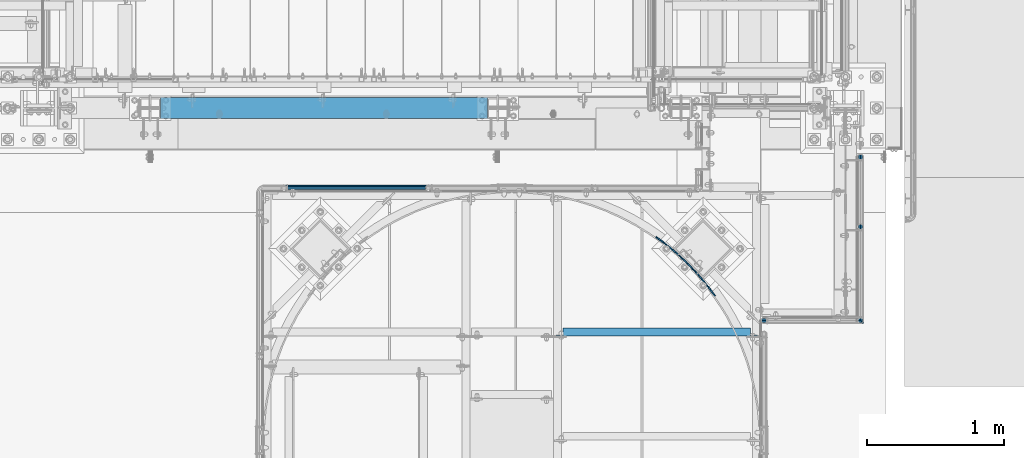
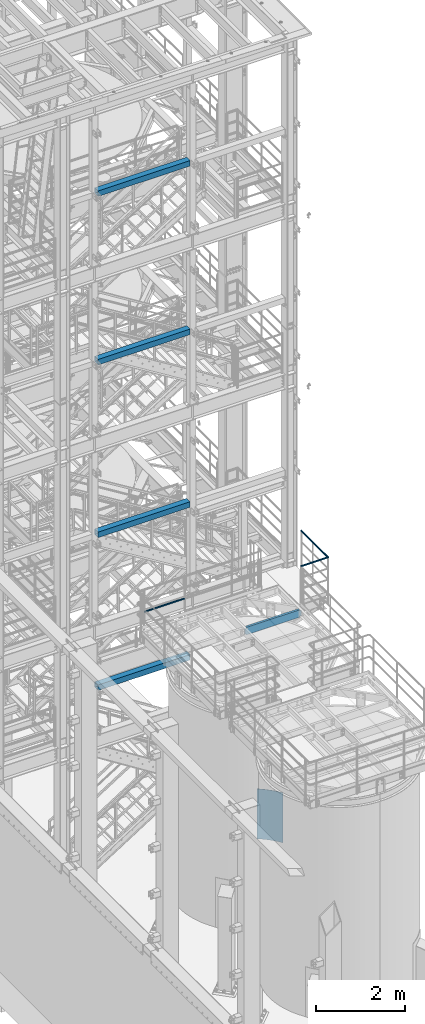
# One storey, part 943 of 1876: 8 beams, 8 elements without a shape of their own.
"""IFC2X3 building model written with IfcOpenShell, lengths in millimetres."""

import ifcopenshell
import ifcopenshell.guid

model = None  # the IFC model being written
_history = None  # IfcOwnerHistory: only IFC2X3 demands one
_inside = {}  # id of a spatial element -> (the spatial element, [elements in it])
_under = {}  # id of a project, library or spatial element -> (it, [spatial elements below it])
_declared = {}  # id of a project -> (the project, [libraries it declares])
_typed = {}  # id of a type object -> (the type object, [elements of that type])
_made_of = {}  # id of a material, layer set ... -> (it, [elements and type objects made of it])


def new_model(schema):
    """Start an empty IFC model of exactly this schema.

    Asked for "IFC4X3", IfcOpenShell would pick the latest addendum, in which some entities
    have other attributes; the version numbers below select the first issue.
    IFC2X3 requires an IfcOwnerHistory on every rooted entity: one is made here for all.
    """
    global model, _history
    if schema == "IFC4X3":
        model = ifcopenshell.file(schema_version=(4, 3, 0, 0))
    else:
        model = ifcopenshell.file(schema=schema)
    _inside.clear()
    _under.clear()
    _declared.clear()
    _typed.clear()
    _made_of.clear()
    _history = None
    if model.schema == "IFC2X3":
        org = make("IfcOrganization", Name="unknown")
        user = make(
            "IfcPersonAndOrganization",
            ThePerson=make("IfcPerson", FamilyName="unknown"),
            TheOrganization=org,
        )
        app = make(
            "IfcApplication",
            ApplicationDeveloper=org,
            Version="unknown",
            ApplicationFullName="unknown",
            ApplicationIdentifier="unknown",
        )
        _history = make(
            "IfcOwnerHistory",
            OwningUser=user,
            OwningApplication=app,
            ChangeAction="ADDED",
            CreationDate=0,
        )
    return model


def make(cls, **values):
    """One entity of the class cls with the attributes given. An attribute that is None is left unset."""
    return model.create_entity(
        cls, **{name: value for name, value in values.items() if value is not None}
    )


def rooted(cls, **values):
    """An entity with a GlobalId (a new one), such as an element, a storey or a relation."""
    return make(cls, GlobalId=ifcopenshell.guid.new(), OwnerHistory=_history, **values)


def si_unit(unit_type, name, prefix=None):
    """IfcSIUnit, for example si_unit("LENGTHUNIT", "METRE", prefix="MILLI")."""
    return make("IfcSIUnit", UnitType=unit_type, Prefix=prefix, Name=name)


def assignment(units):
    """IfcUnitAssignment: the units of a project."""
    return None if units is None else make("IfcUnitAssignment", Units=units)


def point(xyz):
    """IfcCartesianPoint."""
    return None if xyz is None else make("IfcCartesianPoint", Coordinates=xyz)


def direction(xyz):
    """IfcDirection."""
    return None if xyz is None else make("IfcDirection", DirectionRatios=xyz)


def frame(location, z_axis=None, x_axis=None):
    """IfcAxis2Placement3D, a coordinate frame: its origin and axes. An axis left out is left unset."""
    return make(
        "IfcAxis2Placement3D",
        Location=point(location),
        Axis=direction(z_axis),
        RefDirection=direction(x_axis),
    )


def origin_with_axes():
    """The frame at (0, 0, 0) with the z axis (0, 0, 1) and the x axis (1, 0, 0) written out."""
    return frame((0.0, 0.0, 0.0), z_axis=(0.0, 0.0, 1.0), x_axis=(1.0, 0.0, 0.0))


def place(relative_to, where):
    """IfcLocalPlacement: puts the frame where relative to a parent placement (None: the world)."""
    return make(
        "IfcLocalPlacement", PlacementRelTo=relative_to, RelativePlacement=where
    )


def context(
    kind, dimensions, precision=None, world=None, true_north=None, identifier=None
):
    """IfcGeometricRepresentationContext, for example the 3D "Model" context."""
    return make(
        "IfcGeometricRepresentationContext",
        ContextIdentifier=identifier,
        ContextType=kind,
        CoordinateSpaceDimension=dimensions,
        Precision=precision,
        WorldCoordinateSystem=world,
        TrueNorth=true_north,
    )


def subcontext(parent, identifier, kind, view, scale=None):
    """IfcGeometricRepresentationSubContext, for example "Body" below "Model"."""
    return make(
        "IfcGeometricRepresentationSubContext",
        ContextIdentifier=identifier,
        ContextType=kind,
        ParentContext=parent,
        TargetScale=scale,
        TargetView=view,
    )


def project(units=None, contexts=None):
    """IfcProject with its units and contexts."""
    return rooted(
        "IfcProject",
        Name="project",
        RepresentationContexts=contexts,
        UnitsInContext=assignment(units),
    )


def spatial(cls, under=None, at=None, **own):
    """A site, building, storey or space (cls), placed at a placement, below another one or the project."""
    s = rooted(cls, ObjectPlacement=at, **own)
    if under is not None:
        _under.setdefault(under.id(), (under, []))[1].append(s)
    return s


def faces_of(points, faces, orient=None, outer=None):
    """IfcFace entities. A face is a list of loops; a loop is a list of indices into points, from 0.

    orient and outer hold one flag for each loop. By default every Orientation is true, the
    first loop of a face is its IfcFaceOuterBound and the others are IfcFaceBound.
    """
    made = []
    for i, loops in enumerate(faces):
        bounds = []
        for j, loop in enumerate(loops):
            is_outer = j == 0 if outer is None else outer[i][j]
            bounds.append(
                make(
                    "IfcFaceOuterBound" if is_outer else "IfcFaceBound",
                    Bound=make("IfcPolyLoop", Polygon=[points[k] for k in loop]),
                    Orientation=True if orient is None else orient[i][j],
                )
            )
        made.append(make("IfcFace", Bounds=bounds))
    return made


def faceted_brep(points, faces, orient=None, outer=None, voids=None):
    """IfcFacetedBrep: a solid bounded by flat faces; with voids (closed shells), ...WithVoids."""
    shared = [point(p) for p in points]
    hull = make("IfcClosedShell", CfsFaces=faces_of(shared, faces, orient, outer))
    if voids is None:
        return make("IfcFacetedBrep", Outer=hull)
    return make(
        "IfcFacetedBrepWithVoids",
        Outer=hull,
        Voids=[
            make(cls, CfsFaces=faces_of(shared, fs, o, b)) for cls, fs, o, b in voids
        ],
    )


def shape(context_of_items, identifier, shape_type, items):
    """IfcShapeRepresentation: the items that make up one representation, for example the "Body"."""
    return make(
        "IfcShapeRepresentation",
        ContextOfItems=context_of_items,
        RepresentationIdentifier=identifier,
        RepresentationType=shape_type,
        Items=items,
    )


def material(Name=None, Category=None):
    """IfcMaterial."""
    return make("IfcMaterial", Name=Name, Category=Category)


def made_of(thing, what):
    """Note that an element or type object is made of a material, layer set ...; save() writes the relation."""
    if what is not None:
        _made_of.setdefault(what.id(), (what, []))[1].append(thing)
    return thing


def type_object(cls, material=None, **own):
    """A type object (cls), such as IfcWallType, which elements share."""
    return made_of(rooted(cls, **own), material)


def element(
    cls,
    number,
    at=None,
    inside=None,
    cuts=None,
    type_object=None,
    material=None,
    context=None,
    identifier="Body",
    shape_type=None,
    held_by="IfcProductDefinitionShape",
    body=None,
    shapes=None,
    **own,
):
    """One element of the class cls, such as IfcWall. Its Tag is "e" and its number.

    at: its placement. inside: the storey or other place that contains it. cuts: it is an
    opening in that element (IfcRelVoidsElement). A single representation is given by context,
    identifier, shape_type and body (its items); several are given by shapes. held_by: the class
    of the entity that holds the representations. save() writes the other relations.
    """
    e = rooted(cls, Tag="e%d" % number, ObjectPlacement=at, **own)
    if body is not None:
        shapes = [shape(context, identifier, shape_type, body)]
    if shapes is not None:
        e.Representation = make(held_by, Representations=shapes)
    if inside is not None:
        _inside.setdefault(inside.id(), (inside, []))[1].append(e)
    if cuts is not None:
        rooted(
            "IfcRelVoidsElement", RelatingBuildingElement=cuts, RelatedOpeningElement=e
        )
    if type_object is not None:
        _typed.setdefault(type_object.id(), (type_object, []))[1].append(e)
    return made_of(e, material)


def aggregate(whole, parts):
    """IfcRelAggregates: a whole, such as a stair, and the parts it consists of."""
    return rooted("IfcRelAggregates", RelatingObject=whole, RelatedObjects=parts)


def save(model, path):
    """Write the relations noted so far, then the file.

    IfcRelAggregates (storeys below a building ...), IfcRelContainedInSpatialStructure (elements
    in a storey), IfcRelDefinesByType, IfcRelAssociatesMaterial and IfcRelDeclares: one each for
    every whole, place, type object, material and project.
    """
    for whole, parts in _under.values():
        aggregate(whole, parts)
    for where, things in _inside.values():
        rooted(
            "IfcRelContainedInSpatialStructure",
            RelatedElements=things,
            RelatingStructure=where,
        )
    for kind, things in _typed.values():
        rooted("IfcRelDefinesByType", RelatedObjects=things, RelatingType=kind)
    for what, things in _made_of.values():
        rooted("IfcRelAssociatesMaterial", RelatedObjects=things, RelatingMaterial=what)
    for by, libraries in _declared.values():
        rooted("IfcRelDeclares", RelatingContext=by, RelatedDefinitions=libraries)
    model.write(path)


model = new_model("IFC2X3")

# Units and contexts
model_context = context("Model", 3, precision=1e-05, world=origin_with_axes())
body_context = subcontext(model_context, "Body", "Model", "MODEL_VIEW")
ifc_project = project(units=[si_unit("LENGTHUNIT", "METRE", prefix="MILLI"), si_unit("AREAUNIT", "SQUARE_METRE"), si_unit("VOLUMEUNIT", "CUBIC_METRE"), si_unit("MASSUNIT", "GRAM", prefix="KILO"), si_unit("TIMEUNIT", "SECOND"), si_unit("PLANEANGLEUNIT", "RADIAN"), si_unit("SOLIDANGLEUNIT", "STERADIAN"), si_unit("THERMODYNAMICTEMPERATUREUNIT", "DEGREE_CELSIUS"), si_unit("LUMINOUSINTENSITYUNIT", "LUMEN")], contexts=[model_context])

# Site, building, storey
site_placement = place(None, origin_with_axes())
site = spatial("IfcSite", under=ifc_project, at=site_placement, CompositionType="ELEMENT")
building_placement = place(site_placement, origin_with_axes())
building = spatial("IfcBuilding", under=site, at=building_placement, Name="Undefined", CompositionType="ELEMENT")
storey_placement = place(building_placement, origin_with_axes())
storey = spatial("IfcBuildingStorey", under=building, at=storey_placement, Name="Undefined", CompositionType="ELEMENT", Elevation=0.0)

# Assembly, beam
assembly_1_placement = place(storey_placement, origin_with_axes())
assembly_1 = element("IfcElementAssembly", 1, at=assembly_1_placement, inside=storey, Name="FRAME", AssemblyPlace="NOTDEFINED", PredefinedType="RIGID_FRAME")
ifc_material_1 = material()
beam_type_1 = type_object("IfcBeamType", Name="HSS6X6X3/8", PredefinedType="NOTDEFINED")
beam_1_placement = place(assembly_1_placement, frame((2540.0, -7112.0, 19958.05), z_axis=(0.0, 1.0, 0.0), x_axis=(1.0, 0.0, 0.0)))
beam_1 = element("IfcBeam", 2, at=beam_1_placement, type_object=beam_type_1, material=ifc_material_1, Name="FRAME", ObjectType="HSS6X6X3/8", context=body_context, shape_type="Brep", body=[
    faceted_brep([(76.2000000000007, 66.6749999999993, -66.6750000000002), (76.2000000000007, -66.6749999999993, -66.6750000000002), (2463.8, -66.6749999999993, -66.6750000000002), (2463.8, 66.6749999999993, -66.6750000000002), (76.2000000000007, -66.6749999999993, 66.6750000000002), (2463.8, -66.6749999999993, 66.6750000000002), (76.2000000000007, 66.6749999999993, 66.6750000000002), (2463.8, 66.6749999999993, 66.6750000000002), (76.2000000000007, 76.2000000000007, -76.1999999999998), (76.2000000000007, 76.2000000000007, 76.1999999999998), (2463.8, 76.2000000000007, 76.1999999999998), (2463.8, 76.2000000000007, -76.1999999999998), (76.2000000000007, -76.2000000000007, 76.1999999999998), (2463.8, -76.2000000000007, 76.1999999999998), (76.2000000000007, -76.2000000000007, -76.1999999999998), (2463.8, -76.2000000000007, -76.1999999999998)], [[[0, 1, 2, 3]], [[1, 4, 5, 2]], [[4, 6, 7, 5]], [[6, 0, 3, 7]], [[8, 9, 10, 11]], [[9, 12, 13, 10]], [[12, 14, 15, 13]], [[14, 8, 11, 15]], [[13, 15, 11, 10], [5, 7, 3, 2]], [[14, 12, 9, 8], [6, 4, 1, 0]]]),
])
aggregate(assembly_1, [beam_1])

assembly_2_placement = place(storey_placement, origin_with_axes())
assembly_2 = element("IfcElementAssembly", 3, at=assembly_2_placement, inside=storey, Name="FRAME", AssemblyPlace="NOTDEFINED", PredefinedType="RIGID_FRAME")
beam_2_placement = place(assembly_2_placement, frame((2540.0, -7112.0, 15335.25), z_axis=(0.0, 1.0, 0.0), x_axis=(1.0, 0.0, 0.0)))
beam_2 = element("IfcBeam", 4, at=beam_2_placement, type_object=beam_type_1, material=ifc_material_1, Name="FRAME", ObjectType="HSS6X6X3/8", context=body_context, shape_type="Brep", body=[
    faceted_brep([(76.2000000000007, 66.6749999999993, -66.6750000000002), (76.2000000000007, -66.6749999999993, -66.6750000000002), (2463.8, -66.6749999999993, -66.6750000000002), (2463.8, 66.6749999999993, -66.6750000000002), (76.2000000000007, -66.6749999999993, 66.6750000000002), (2463.8, -66.6749999999993, 66.6750000000002), (76.2000000000007, 66.6749999999993, 66.6750000000002), (2463.8, 66.6749999999993, 66.6750000000002), (76.2000000000007, 76.2000000000007, -76.1999999999998), (76.2000000000007, 76.2000000000007, 76.1999999999998), (2463.8, 76.2000000000007, 76.1999999999998), (2463.8, 76.2000000000007, -76.1999999999998), (76.2000000000007, -76.2000000000007, 76.1999999999998), (2463.8, -76.2000000000007, 76.1999999999998), (76.2000000000007, -76.2000000000007, -76.1999999999998), (2463.8, -76.2000000000007, -76.1999999999998)], [[[0, 1, 2, 3]], [[1, 4, 5, 2]], [[4, 6, 7, 5]], [[6, 0, 3, 7]], [[8, 9, 10, 11]], [[9, 12, 13, 10]], [[12, 14, 15, 13]], [[14, 8, 11, 15]], [[13, 15, 11, 10], [5, 7, 3, 2]], [[14, 12, 9, 8], [6, 4, 1, 0]]]),
])
aggregate(assembly_2, [beam_2])

assembly_3_placement = place(storey_placement, origin_with_axes())
assembly_3 = element("IfcElementAssembly", 5, at=assembly_3_placement, inside=storey, Name="FRAME", AssemblyPlace="NOTDEFINED", PredefinedType="RIGID_FRAME")
beam_3_placement = place(assembly_3_placement, frame((2540.0, -7112.0, 10598.15), z_axis=(0.0, 1.0, 0.0), x_axis=(1.0, 0.0, 0.0)))
beam_3 = element("IfcBeam", 6, at=beam_3_placement, type_object=beam_type_1, material=ifc_material_1, Name="FRAME", ObjectType="HSS6X6X3/8", context=body_context, shape_type="Brep", body=[
    faceted_brep([(76.2000000000007, 66.6749999999993, -66.6750000000002), (76.2000000000007, -66.6749999999993, -66.6750000000002), (2463.8, -66.6749999999993, -66.6750000000002), (2463.8, 66.6749999999993, -66.6750000000002), (76.2000000000007, -66.6749999999993, 66.6750000000002), (2463.8, -66.6749999999993, 66.6750000000002), (76.2000000000007, 66.6749999999993, 66.6750000000002), (2463.8, 66.6749999999993, 66.6750000000002), (76.2000000000007, 76.2000000000007, -76.1999999999998), (76.2000000000007, 76.2000000000007, 76.1999999999998), (2463.8, 76.2000000000007, 76.1999999999998), (2463.8, 76.2000000000007, -76.1999999999998), (76.2000000000007, -76.2000000000007, 76.1999999999998), (2463.8, -76.2000000000007, 76.1999999999998), (76.2000000000007, -76.2000000000007, -76.1999999999998), (2463.8, -76.2000000000007, -76.1999999999998)], [[[0, 1, 2, 3]], [[1, 4, 5, 2]], [[4, 6, 7, 5]], [[6, 0, 3, 7]], [[8, 9, 10, 11]], [[9, 12, 13, 10]], [[12, 14, 15, 13]], [[14, 8, 11, 15]], [[13, 15, 11, 10], [5, 7, 3, 2]], [[14, 12, 9, 8], [6, 4, 1, 0]]]),
])
aggregate(assembly_3, [beam_3])

assembly_4_placement = place(storey_placement, origin_with_axes())
assembly_4 = element("IfcElementAssembly", 7, at=assembly_4_placement, inside=storey, Name="FRAME", AssemblyPlace="NOTDEFINED", PredefinedType="RIGID_FRAME")
beam_4_placement = place(assembly_4_placement, frame((2539.98075746042, -7112.0, 6407.15001063849), z_axis=(0.0, 1.0, 0.0), x_axis=(1.0, 0.0, 0.0)))
beam_4 = element("IfcBeam", 8, at=beam_4_placement, type_object=beam_type_1, material=ifc_material_1, Name="FRAME", ObjectType="HSS6X6X3/8", context=body_context, shape_type="Brep", body=[
    faceted_brep([(76.2192425395833, 66.6750000000002, -66.6750000000002), (76.2192425395833, -66.6750000000002, -66.6750000000002), (2463.81924253958, -66.6750000000002, -66.6750000000002), (2463.81924253958, 66.6750000000002, -66.6750000000002), (76.2192425395833, -66.6750000000002, 66.6750000000002), (2463.81924253958, -66.6750000000002, 66.6750000000002), (76.2192425395833, 66.6750000000002, 66.6750000000002), (2463.81924253958, 66.6750000000002, 66.6750000000002), (76.2192425395833, 76.1999999999998, -76.1999999999998), (76.2192425395833, 76.1999999999998, 76.1999999999998), (2463.81924253958, 76.1999999999998, 76.1999999999998), (2463.81924253958, 76.1999999999998, -76.1999999999998), (76.2192425395833, -76.1999999999998, 76.1999999999998), (2463.81924253958, -76.1999999999998, 76.1999999999998), (76.2192425395833, -76.1999999999998, -76.1999999999998), (2463.81924253958, -76.1999999999998, -76.1999999999998)], [[[0, 1, 2, 3]], [[1, 4, 5, 2]], [[4, 6, 7, 5]], [[6, 0, 3, 7]], [[8, 9, 10, 11]], [[9, 12, 13, 10]], [[12, 14, 15, 13]], [[14, 8, 11, 15]], [[13, 15, 11, 10], [5, 7, 3, 2]], [[14, 12, 9, 8], [6, 4, 1, 0]]]),
])
aggregate(assembly_4, [beam_4])

assembly_5_placement = place(storey_placement, origin_with_axes())
assembly_5 = element("IfcElementAssembly", 9, at=assembly_5_placement, inside=storey, Name="HANDRAIL", AssemblyPlace="NOTDEFINED", PredefinedType="RIGID_FRAME")
ifc_material_2 = material()
beam_type_2 = type_object("IfcBeamType", Name="PIPE1-1/4STD", PredefinedType="NOTDEFINED")
beam_5_placement = place(assembly_5_placement, frame((7729.98183904197, -7448.10549924137, 9090.025), z_axis=(0.0, 0.0, -1.0), x_axis=(0.0, -1.0, 0.0)))
beam_5 = element("IfcBeam", 10, at=beam_5_placement, type_object=beam_type_2, material=ifc_material_2, Name="HANDRAIL", ObjectType="PIPE1-1/4STD", context=body_context, shape_type="Brep", body=[
    faceted_brep([(1193.74453528923, -10.5410005254334, -18.2575475625872), (1193.74453528583, -18.2575480880168, -10.5410000000029), (10.5409999957128, -18.2575475672238, -10.5409999999993), (2.8244524331285, -10.5410000012434, -18.2575475625836), (1193.74453529387, -5.25433279108256e-07, -21.082000000004), (-4.28826751885936e-09, 0.0, -21.0820000000003), (1193.74453529851, 10.5409994745669, -18.2575475625872), (2.8244524331285, 10.5409999987578, -18.2575475625836), (1193.7445353019, 18.2575470371494, -10.5410000000029), (10.5409999957128, 18.2575475579433, -10.5409999999993), (1193.74453530315, 21.0819994745652, -3.63797880709171e-12), (21.081999995713, 21.0819999907208, 0.0), (1193.7445353019, 18.2575470371494, 10.5409999999956), (31.6229999957131, 18.2575475486638, 10.5409999999993), (1193.74453529851, 10.5409994745669, 18.2575475625799), (39.3395475582975, 10.5409999826852, 18.2575475625836), (1193.74453529387, -5.25433279108256e-07, 21.0819999999967), (42.1639999957133, -1.85582393896766e-08, 21.0820000000003), (1193.74453528923, -10.5410005254334, 18.2575475625799), (39.3395475582965, -10.541000017316, 18.2575475625836), (1193.74453528583, -18.2575480880168, 10.5409999999956), (31.6229999957131, -18.2575475765025, 10.5409999999993), (1193.74453528459, -21.0820005254336, -3.63797880709171e-12), (21.0819999957121, -21.0820000092799, 0.0), (1193.74453529772, 8.76299947456664, 15.1779612267219), (1193.74453529387, -5.25433279108256e-07, 17.5259999999962), (38.6079999957128, -1.69929990079254e-08, 17.5259999999998), (36.2599612224385, 8.76299998404011, 15.1779612267255), (1193.74453530055, 15.1779607012913, 8.76299999999719), (29.8449999957138, 15.1779612135888, 8.76299999999901), (1193.74453530158, 17.5259994745657, -3.63797880709171e-12), (21.0819999957121, 17.5259999907203, 0.0), (1193.74453530055, 15.1779607012913, -8.76300000000447), (12.3189999957121, 15.1779612213031, -8.76300000000083), (1193.74453529772, 8.76299947456664, -15.1779612267292), (5.90403876898654, 8.76299999740149, -15.1779612267255), (1193.74453529387, -5.25433279108256e-07, -17.5260000000035), (3.55599999571223, -1.56524038175121e-09, -17.5259999999998), (1193.74453529001, -8.7630005254332, -15.1779612267292), (5.90403876898563, -8.76300000259835, -15.1779612267255), (1193.74453528718, -15.1779617521597, -8.76300000000447), (12.3189999957121, -15.1779612321488, -8.76300000000083), (1193.74453528615, -17.5260005254331, -3.63797880709171e-12), (21.0819999957121, -17.5260000092794, 0.0), (1193.74453528718, -15.1779617521597, 8.76299999999719), (29.8449999957129, -15.1779612398623, 8.76299999999901), (1193.74453529001, -8.7630005254332, 15.1779612267219), (36.2599612224394, -8.76300001595973, 15.1779612267255), (1233.58408805855, -18.2575481055537, -10.5410000000029), (1236.4085408688, -21.0820005442129, -3.63797880709171e-12), (1225.86753947738, -10.5410005395725, -18.2575475625872), (1215.32653808597, -5.34932951268274e-07, -21.082000000004), (1204.78553669456, 10.5409994697075, -18.2575475625872), (1197.06898811339, 18.2575470356869, -10.5410000000029), (1194.24453530315, 21.081999474346, -3.63797880709171e-12), (1197.06898811339, 18.2575470356869, 10.5409999999956), (1204.78553669456, 10.5409994697075, 18.2575475625799), (1215.32653808597, -5.34932951268274e-07, 21.0819999999967), (1225.86753947738, -10.5410005395734, 18.2575475625799), (1233.58408805855, -18.2575481055537, 10.5409999999956), (1230.50450131619, -15.1779617683396, 8.76299999999719), (1232.8525403994, -17.5260005426471, -3.63797880709171e-12), (1224.08953924269, -8.76300053879004, 15.1779612267219), (1215.32653808597, -5.34932951268274e-07, 17.5259999999962), (1206.56353692925, 8.76299946892414, 15.1779612267219), (1200.14857485575, 15.1779606984728, 8.76299999999719), (1197.80053577254, 17.5259994727803, -3.63797880709171e-12), (1200.14857485575, 15.1779606984728, -8.76300000000447), (1206.56353692925, 8.76299946892414, -15.1779612267292), (1215.32653808597, -5.34932951268274e-07, -17.5260000000035), (1224.08953924269, -8.76300053879004, -15.1779612267292), (1230.50450131619, -15.1779617683396, -8.76300000000447), (1233.58408279973, 21.5820046671661, -10.5410000000029), (1236.40853523715, 21.5820050399943, -3.63797880709171e-12), (1225.86753523715, 21.582003648582, -18.2575475625872), (1215.32653523715, 21.5820022571697, -21.082000000004), (1204.78553523715, 21.5820008657583, -18.2575475625872), (1197.06898767456, 21.5819998471743, -10.5410000000029), (1194.24453523715, 21.581999474346, -3.63797880709171e-12), (1197.06898767456, 21.5819998471743, 10.5409999999956), (1204.78553523715, 21.5820008657583, 18.2575475625799), (1215.32653523715, 21.5820022571697, 21.0819999999967), (1225.86753523715, 21.582003648582, 18.2575475625799), (1233.58408279973, 21.5820046671661, 10.5409999999956), (1230.50449646387, 21.5820042606611, 8.76299999999719), (1232.85253523715, 21.5820045706023, -3.63797880709171e-12), (1224.08953523715, 21.582003413886, 15.1779612267219), (1215.32653523715, 21.5820022571697, 17.5259999999962), (1206.56353523715, 21.5820011004544, 15.1779612267219), (1200.14857401042, 21.5820002536793, 8.76299999999719), (1197.80053523715, 21.5819999437381, -3.63797880709171e-12), (1200.14857401042, 21.5820002536793, -8.76300000000447), (1206.56353523715, 21.5820011004544, -15.1779612267292), (1215.32653523715, 21.5820022571697, -17.5260000000035), (1224.08953523715, 21.582003413886, -15.1779612267292), (1230.50449646387, 21.5820042606611, -8.76300000000447), (1236.40844504602, 704.848119312714, -1.81898940354586e-12), (1233.58399400001, 694.307118939885, 10.5409999999974), (1225.86744745601, 686.590570358717, 18.2575475625817), (1215.32644782884, 683.766116529889, 21.0819999999985), (1204.78544745601, 686.590567575893, 18.2575475625817), (1197.06889887485, 694.307114119893, 10.5409999999974), (1194.24444504602, 704.848113747065, -1.81898940354586e-12), (1197.06889609202, 715.389114119893, -10.5410000000011), (1204.78544263602, 723.105662701061, -18.2575475625854), (1215.3264422632, 725.930116529889, -21.0820000000022), (1225.86744263602, 723.105665483885, -18.2575475625854), (1233.58399121719, 715.389118939885, -10.5410000000011), (1232.85244504602, 704.848118843322, -1.81898940354586e-12), (1230.50440511603, 713.61111853338, -8.76300000000265), (1224.08944304253, 720.026078913331, -15.1779612267273), (1215.32644273259, 722.374116529889, -17.5260000000017), (1206.56344304253, 720.026076599899, -15.1779612267273), (1200.14848266258, 713.611114526399, -8.76300000000265), (1197.80044504602, 704.848114216457, -1.81898940354586e-12), (1200.14848497601, 696.085114526398, 8.76299999999901), (1206.56344704951, 689.670154146447, 15.1779612267237), (1215.32644735945, 687.322116529888, 17.525999999998), (1224.08944704951, 689.670156459879, 15.1779612267237), (1230.50440742946, 696.08511853338, 8.76299999999901)], [[[0, 1, 2, 3]], [[4, 0, 3, 5]], [[6, 4, 5, 7]], [[8, 6, 7, 9]], [[10, 8, 9, 11]], [[12, 10, 11, 13]], [[14, 12, 13, 15]], [[16, 14, 15, 17]], [[18, 16, 17, 19]], [[20, 18, 19, 21]], [[22, 20, 21, 23]], [[1, 22, 23, 2]], [[24, 25, 26, 27]], [[28, 24, 27, 29]], [[30, 28, 29, 31]], [[32, 30, 31, 33]], [[34, 32, 33, 35]], [[36, 34, 35, 37]], [[38, 36, 37, 39]], [[40, 38, 39, 41]], [[42, 40, 41, 43]], [[44, 42, 43, 45]], [[46, 44, 45, 47]], [[25, 46, 47, 26]], [[13, 11, 9, 7, 5, 3, 2, 23, 21, 19, 17, 15], [45, 43, 41, 39, 37, 35, 33, 31, 29, 27, 26, 47]], [[22, 1, 48, 49]], [[1, 0, 50, 48]], [[0, 4, 51, 50]], [[4, 6, 52, 51]], [[6, 8, 53, 52]], [[8, 10, 54, 53]], [[10, 12, 55, 54]], [[12, 14, 56, 55]], [[14, 16, 57, 56]], [[16, 18, 58, 57]], [[18, 20, 59, 58]], [[20, 22, 49, 59]], [[42, 44, 60, 61]], [[44, 46, 62, 60]], [[46, 25, 63, 62]], [[25, 24, 64, 63]], [[24, 28, 65, 64]], [[28, 30, 66, 65]], [[30, 32, 67, 66]], [[32, 34, 68, 67]], [[34, 36, 69, 68]], [[36, 38, 70, 69]], [[38, 40, 71, 70]], [[40, 42, 61, 71]], [[49, 48, 72, 73]], [[48, 50, 74, 72]], [[50, 51, 75, 74]], [[51, 52, 76, 75]], [[52, 53, 77, 76]], [[53, 54, 78, 77]], [[54, 55, 79, 78]], [[55, 56, 80, 79]], [[56, 57, 81, 80]], [[57, 58, 82, 81]], [[58, 59, 83, 82]], [[59, 49, 73, 83]], [[61, 60, 84, 85]], [[60, 62, 86, 84]], [[62, 63, 87, 86]], [[63, 64, 88, 87]], [[64, 65, 89, 88]], [[65, 66, 90, 89]], [[66, 67, 91, 90]], [[67, 68, 92, 91]], [[68, 69, 93, 92]], [[69, 70, 94, 93]], [[70, 71, 95, 94]], [[71, 61, 85, 95]], [[83, 73, 96, 97]], [[82, 83, 97, 98]], [[81, 82, 98, 99]], [[80, 81, 99, 100]], [[79, 80, 100, 101]], [[78, 79, 101, 102]], [[77, 78, 102, 103]], [[76, 77, 103, 104]], [[75, 76, 104, 105]], [[74, 75, 105, 106]], [[72, 74, 106, 107]], [[73, 72, 107, 96]], [[95, 85, 108, 109]], [[94, 95, 109, 110]], [[93, 94, 110, 111]], [[92, 93, 111, 112]], [[91, 92, 112, 113]], [[90, 91, 113, 114]], [[89, 90, 114, 115]], [[88, 89, 115, 116]], [[87, 88, 116, 117]], [[86, 87, 117, 118]], [[84, 86, 118, 119]], [[85, 84, 119, 108]], [[106, 105, 104, 103, 102, 101, 100, 99, 98, 97, 96, 107], [118, 117, 116, 115, 114, 113, 112, 111, 110, 109, 108, 119]]]),
])
aggregate(assembly_5, [beam_5])

assembly_6_placement = place(storey_placement, origin_with_axes())
assembly_6 = element("IfcElementAssembly", 11, at=assembly_6_placement, inside=storey, Name="HANDRAIL", AssemblyPlace="NOTDEFINED", PredefinedType="RIGID_FRAME")
beam_6_placement = place(assembly_6_placement, frame((3517.90474593762, -7694.13240429563, 8480.425), z_axis=(0.0, 0.0, 1.0), x_axis=(1.0, 0.0, 0.0)))
beam_6 = element("IfcBeam", 12, at=beam_6_placement, type_object=beam_type_2, material=ifc_material_2, Name="RAIL", ObjectType="PIPE1-1/4STD", context=body_context, shape_type="Brep", body=[
    faceted_brep([(1035.84245243742, -10.5409999999993, 18.2575475625836), (1035.84245243742, -10.5409999999993, 13.3999612267253), (1035.36603877327, -8.76300000000083, 15.1779612267255), (1033.018, 0.0, 17.5259999999998), (1033.018, 0.0, 21.0820000000003), (1035.36603877327, 8.76300000000083, 15.1779612267255), (1035.84245243742, 10.5409999999993, 13.3999612267253), (1035.84245243742, 10.5409999999993, 18.2575475625836), (1054.1, 21.0820000000003, 0.0), (1043.559, 18.2575475625836, 10.5409999999993), (1043.559, 18.2575475625836, -10.5409999999993), (1040.47941366414, 15.1779612267255, 8.76300000000083), (1042.82745243742, 17.5259999999998, 0.0), (1040.47941366414, 15.1779612267255, -8.76300000000083), (1035.84245243742, 10.5409999999993, -13.3999612267253), (1035.84245243742, 10.5409999999993, -18.2575475625836), (1035.36603877327, 8.76300000000083, -15.1779612267255), (1033.018, 0.0, -17.5259999999998), (1033.018, 0.0, -21.0820000000003), (1035.84245243742, -10.5409999999993, -13.3999612267253), (1035.84245243742, -10.5409999999993, -18.2575475625836), (1035.36603877327, -8.76300000000083, -15.1779612267255), (1054.1, -21.0820000000003, 0.0), (1043.559, -18.2575475625836, -10.5409999999993), (1043.559, -18.2575475625836, 10.5409999999993), (1040.47941366414, -15.1779612267255, -8.76300000000083), (1042.82745243742, -17.5259999999998, 0.0), (1040.47941366414, -15.1779612267255, 8.76300000000083), (10.5409999957128, -18.2575475672238, -10.5409999999993), (18.2575475625817, -10.5410000000011, -18.2575475625836), (9.09494701772928e-13, 21.0820000000003, 0.0), (10.5409999957128, 18.2575475579433, -10.5409999999993), (10.5409999999983, 18.2575475625836, 10.5410000000011), (18.2575475625817, 10.5409999999993, 18.2575475625836), (21.0819999999985, 1.81898940354586e-12, 21.0820000000003), (18.2575475625817, 10.5409999999993, -18.2575475625836), (21.0819999999985, 0.0, -21.0819999999985), (21.0819999999985, 0.0, -17.5259999999998), (18.2575475625817, -10.5409999999974, -13.3999612267271), (18.7339612267233, -8.76300000000083, -15.1779612267255), (18.7339612267251, 8.76299999999901, -15.1779612267255), (18.2575475625817, 10.5410000000011, -13.3999612267235), (13.6205863358573, 15.1779612267255, -8.76299999999901), (11.2725475625839, 17.5259999999998, 0.0), (13.6205863358573, 15.1779612267255, 8.76300000000083), (18.2575475625817, 10.5410000000011, 13.3999612267253), (18.7339612267251, 8.76299999999901, 15.1779612267273), (21.0819999999985, 1.81898940354586e-12, 17.5259999999998), (18.7339612267233, -8.76300000000083, 15.1779612267273), (18.2575475625817, -10.5409999999974, 13.3999612267289), (18.2575475625817, -10.5410000000011, 18.2575475625836), (10.5409999999983, -18.2575475625836, 10.5410000000011), (9.09494701772928e-13, -21.0820000000003, 0.0), (13.6205863358537, -15.1779612267255, 8.76300000000083), (11.2725475625793, -17.5259999999998, 0.0), (13.6205863358537, -15.1779612267255, -8.76299999999901)], [[[0, 1, 2, 3, 4]], [[4, 3, 5, 6, 7]], [[8, 9, 10]], [[7, 6, 11, 12, 13, 14, 15, 10, 9]], [[16, 17, 18, 15, 14]], [[19, 20, 18, 17, 21]], [[22, 23, 24]], [[24, 23, 20, 19, 25, 26, 27, 1, 0]], [[28, 29, 20, 23]], [[30, 31, 32]], [[33, 34, 4, 7]], [[32, 33, 7, 9]], [[30, 32, 9, 8]], [[31, 30, 8, 10]], [[35, 31, 10, 15]], [[36, 35, 15, 18]], [[29, 36, 18, 20]], [[37, 36, 29, 38, 39]], [[40, 41, 35, 36, 37]], [[32, 31, 35, 41, 42, 43, 44, 45, 33]], [[33, 45, 46, 47, 34]], [[34, 47, 48, 49, 50]], [[34, 50, 0, 4]], [[50, 51, 24, 0]], [[51, 52, 22, 24]], [[52, 28, 23, 22]], [[51, 28, 52]], [[50, 49, 53, 54, 55, 38, 29, 28, 51]], [[55, 54, 26, 25]], [[21, 39, 38, 55, 25, 19]], [[37, 39, 21, 17]], [[40, 37, 17, 16]], [[42, 41, 40, 16, 14, 13]], [[43, 42, 13, 12]], [[44, 43, 12, 11]], [[5, 46, 45, 44, 11, 6]], [[47, 46, 5, 3]], [[48, 47, 3, 2]], [[53, 49, 48, 2, 1, 27]], [[54, 53, 27, 26]]]),
])
aggregate(assembly_6, [beam_6])

assembly_7_placement = place(storey_placement, origin_with_axes())
assembly_7 = element("IfcElementAssembly", 13, at=assembly_7_placement, inside=storey, Name="BEAM", AssemblyPlace="NOTDEFINED", PredefinedType="RIGID_FRAME")
ifc_material_3 = material(Name="STEEL/A36")
beam_type_3 = type_object("IfcBeamType", Name="C8X11.5", PredefinedType="NOTDEFINED")
beam_7_placement = place(assembly_7_placement, frame((5486.40333884985, -8747.08935546873, 7896.225), z_axis=(0.0, 0.0, -1.0), x_axis=(1.0, 0.0, 0.0)))
beam_7 = element("IfcBeam", 14, at=beam_7_placement, type_object=beam_type_3, material=ifc_material_3, Name="BEAM", ObjectType="C8X11.5", context=body_context, shape_type="Brep", body=[
    faceted_brep([(57.1500001907361, 22.2250000000004, 76.1999999999989), (57.1500001907361, 28.5750000000007, 76.1999999999989), (19.0499999999993, 28.5750000000007, 76.1999999999989), (19.0499999999993, 22.2250000000004, 76.1999999999989), (62.0100797087816, 22.2250000000004, 77.1667299225865), (62.0100797087816, 28.5750000000007, 77.1667299225865), (66.1302561769353, 22.2250000000004, 79.9197438230649), (66.1302561769353, 28.5750000000007, 79.9197438230649), (68.8832700774137, 22.2250000000004, 84.0399202912186), (68.8832700774137, 28.5750000000007, 84.0399202912186), (69.8500000000013, 19.0576241940926, 88.899999809264), (69.8500000000013, 28.5750000000007, 88.899999809264), (69.7450369653607, 22.2250000000004, 88.3723149999996), (69.8500000000013, -28.5750000000007, 101.6), (69.8500000000013, 28.5750000000007, 101.6), (69.8500000000013, -28.5750000000007, 96.8355949999996), (19.0499999999993, 22.2250000000004, -76.2000000000007), (19.0499999999993, 28.5750000000007, -76.2000000000007), (57.1500001907361, 28.5750000000007, -76.2000000000007), (57.1500001907361, 22.2250000000004, -76.2000000000007), (62.0100797087816, 28.5750000000007, -77.1667299225883), (62.0100797087816, 22.2250000000004, -77.1667299225883), (66.1302561769353, 28.5750000000007, -79.9197438230667), (66.1302561769353, 22.2250000000004, -79.9197438230667), (68.8832700774137, 28.5750000000007, -84.0399202912204), (68.8832700774137, 22.2250000000004, -84.0399202912204), (69.7450369653598, 22.2250000000004, -88.3723149999996), (69.8500000000013, 28.5750000000007, -88.8999998092659), (69.8500000000013, 19.0576241940817, -88.8999998092659), (69.8500000000013, -28.5750000000007, -96.8355949999996), (1441.44713699756, -28.5750000000007, -96.8355949999996), (1441.44713699756, 19.0576241940926, -88.899999809264), (1441.5521000322, 22.2250000000004, -88.3723149999996), (1441.44713699756, -28.5750000000007, -101.6), (69.8500000000013, -28.5750000000007, -101.6), (69.8500000000013, 28.5750000000007, -101.6), (1441.44713699756, 28.5750000000007, -101.6), (1441.44713699756, 28.5750000000007, -88.899999809264), (1442.41386692015, 28.5750000000007, -84.0399202912186), (1442.41386692015, 22.2250000000004, -84.0399202912186), (1445.16688082063, 28.5750000000007, -79.9197438230649), (1445.16688082063, 22.2250000000004, -79.9197438230649), (1449.28705728878, 28.5750000000007, -77.1667299225865), (1449.28705728878, 22.2250000000004, -77.1667299225865), (1454.14713680683, 28.5750000000007, -76.1999999999989), (1454.14713680683, 22.2250000000004, -76.1999999999989), (1492.24713699756, 22.2250000000004, -76.1999999999989), (1492.24713699756, 28.5750000000007, -76.1999999999989), (1492.24713699756, 28.5750000000007, 76.2000000000007), (1492.24713699756, 22.2250000000004, 76.2000000000007), (1454.14713680683, 28.5750000000007, 76.2000000000007), (1454.14713680683, 22.2250000000004, 76.2000000000007), (1449.28705728878, 28.5750000000007, 77.1667299225883), (1449.28705728878, 22.2250000000004, 77.1667299225883), (1445.16688082063, 28.5750000000007, 79.9197438230667), (1445.16688082063, 22.2250000000004, 79.9197438230667), (1442.41386692015, 28.5750000000007, 84.0399202912204), (1442.41386692015, 22.2250000000004, 84.0399202912204), (1441.44713699756, 28.5750000000007, 88.8999998092659), (1441.44713699756, 19.0576241940817, 88.8999998092659), (1441.5521000322, 22.2250000000004, 88.3723149999996), (1441.44713699756, -28.5750000000007, 101.6), (1441.44713699756, -28.5750000000007, 96.8355949999996), (1441.44713699756, 28.5750000000007, 101.6)], [[[0, 1, 2, 3]], [[4, 5, 1, 0]], [[6, 7, 5, 4]], [[8, 9, 7, 6]], [[10, 11, 9, 8, 12]], [[13, 14, 11, 10, 15]], [[16, 17, 18, 19]], [[19, 18, 20, 21]], [[21, 20, 22, 23]], [[23, 22, 24, 25]], [[26, 25, 24, 27, 28]], [[29, 30, 31, 32, 26, 28]], [[33, 30, 29, 34]], [[28, 27, 35, 34, 29]], [[36, 33, 34, 35]], [[30, 33, 36, 37, 31]], [[32, 31, 37, 38, 39]], [[39, 38, 40, 41]], [[41, 40, 42, 43]], [[43, 42, 44, 45]], [[46, 45, 44, 47]], [[48, 49, 46, 47]], [[49, 48, 50, 51]], [[51, 50, 52, 53]], [[53, 52, 54, 55]], [[55, 54, 56, 57]], [[57, 56, 58, 59, 60]], [[61, 62, 59, 58, 63]], [[62, 61, 13, 15]], [[12, 60, 59, 62, 15, 10]], [[32, 39, 41, 43, 45, 46, 49, 51, 53, 55, 57, 60, 12, 8, 6, 4, 0, 3, 16, 19, 21, 23, 25, 26]], [[3, 2, 17, 16]], [[22, 20, 18, 17, 2, 1, 5, 7, 9, 11, 14, 63, 58, 56, 54, 52, 50, 48, 47, 44, 42, 40, 38, 37, 36, 35, 27, 24]], [[61, 63, 14, 13]]]),
])
aggregate(assembly_7, [beam_7])

assembly_8_placement = place(storey_placement, origin_with_axes())
assembly_8 = element("IfcElementAssembly", 15, at=assembly_8_placement, inside=storey, Name="COLUMN", AssemblyPlace="NOTDEFINED", PredefinedType="RIGID_FRAME")
beam_type_4 = type_object("IfcBeamType", PredefinedType="NOTDEFINED")
beam_8_placement = place(assembly_8_placement, frame((6234.79283509037, -8052.32780208891, 2209.8), z_axis=(0.0, 0.0, 1.0), x_axis=(0.707106781186547, -0.707106781186548, 0.0)))
beam_8 = element("IfcBeam", 16, at=beam_8_placement, type_object=beam_type_4, material=ifc_material_3, Name="PLATE", context=body_context, shape_type="Brep", body=[
    faceted_brep([(-0.79930179960138, 4.6949465261232, -685.8), (-0.79930179960138, 4.6949465261232, 685.8), (60.0611937621743, 14.0031633272019, 685.8), (60.0611937621743, 14.0031633272019, -685.8), (0.79930179960138, -4.6949465261232, 685.8), (0.79930179960138, -4.6949465261232, -685.8), (61.3422639062264, 4.56470559905301, -685.8), (61.3422639062264, 4.56470559905301, 685.8), (121.200950016122, 21.2538891700888, 685.8), (121.200950016122, 21.2538891700888, -685.8), (122.163029690721, 11.7776015161735, -685.8), (122.163029690721, 11.7776015161735, 685.8), (182.550430177147, 26.4388775030229, 685.8), (182.550430177147, 26.4388775030229, -685.8), (183.192425169107, 16.9355376990206, -685.8), (183.192425169107, 16.9355376990206, 685.8), (244.039858932445, 29.5522312233416, 685.8), (244.039858932445, 29.5522312233416, -685.8), (244.361039074185, 20.0326478124689, -685.8), (244.361039074185, 20.0326478124689, 685.8), (305.599301799859, 30.5904093845011, 685.8), (305.599301799859, 30.5904093845011, -685.8), (305.599301799861, 21.0654093844987, -685.8), (305.599301799861, 21.0654093844987, 685.8), (367.158744667275, 29.5522312233416, 685.8), (367.158744667275, 29.5522312233416, -685.8), (366.837564525536, 20.0326478124671, -685.8), (366.837564525536, 20.0326478124671, 685.8), (428.648173422573, 26.4388775030238, 685.8), (428.648173422573, 26.4388775030238, -685.8), (428.006178430616, 16.9355376990216, -685.8), (428.006178430616, 16.9355376990216, 685.8), (489.997653583598, 21.2538891700897, 685.8), (489.997653583598, 21.2538891700897, -685.8), (489.035573908999, 11.7776015161735, -685.8), (489.035573908999, 11.7776015161735, 685.8), (551.137409837545, 14.0031633272019, 685.8), (551.137409837545, 14.0031633272019, -685.8), (549.856339693495, 4.56470559905301, -685.8), (549.856339693495, 4.56470559905301, 685.8), (611.997905399321, 4.6949465261232, 685.8), (611.997905399321, 4.6949465261232, -685.8), (610.399301800118, -4.69494652612411, 685.8), (610.399301800118, -4.69494652612411, -685.8)], [[[0, 1, 2, 3]], [[4, 5, 6, 7]], [[5, 4, 1, 0]], [[3, 2, 8, 9]], [[7, 6, 10, 11]], [[9, 8, 12, 13]], [[11, 10, 14, 15]], [[13, 12, 16, 17]], [[15, 14, 18, 19]], [[17, 16, 20, 21]], [[19, 18, 22, 23]], [[21, 20, 24, 25]], [[23, 22, 26, 27]], [[25, 24, 28, 29]], [[27, 26, 30, 31]], [[29, 28, 32, 33]], [[31, 30, 34, 35]], [[33, 32, 36, 37]], [[35, 34, 38, 39]], [[37, 36, 40, 41]], [[36, 32, 28, 24, 20, 16, 12, 8, 2, 1, 4, 7, 11, 15, 19, 23, 27, 31, 35, 39, 42, 40]], [[39, 38, 43, 42]], [[38, 34, 30, 26, 22, 18, 14, 10, 6, 5, 0, 3, 9, 13, 17, 21, 25, 29, 33, 37, 41, 43]], [[42, 43, 41, 40]]]),
])
aggregate(assembly_8, [beam_8])

save(model, "model.ifc")
